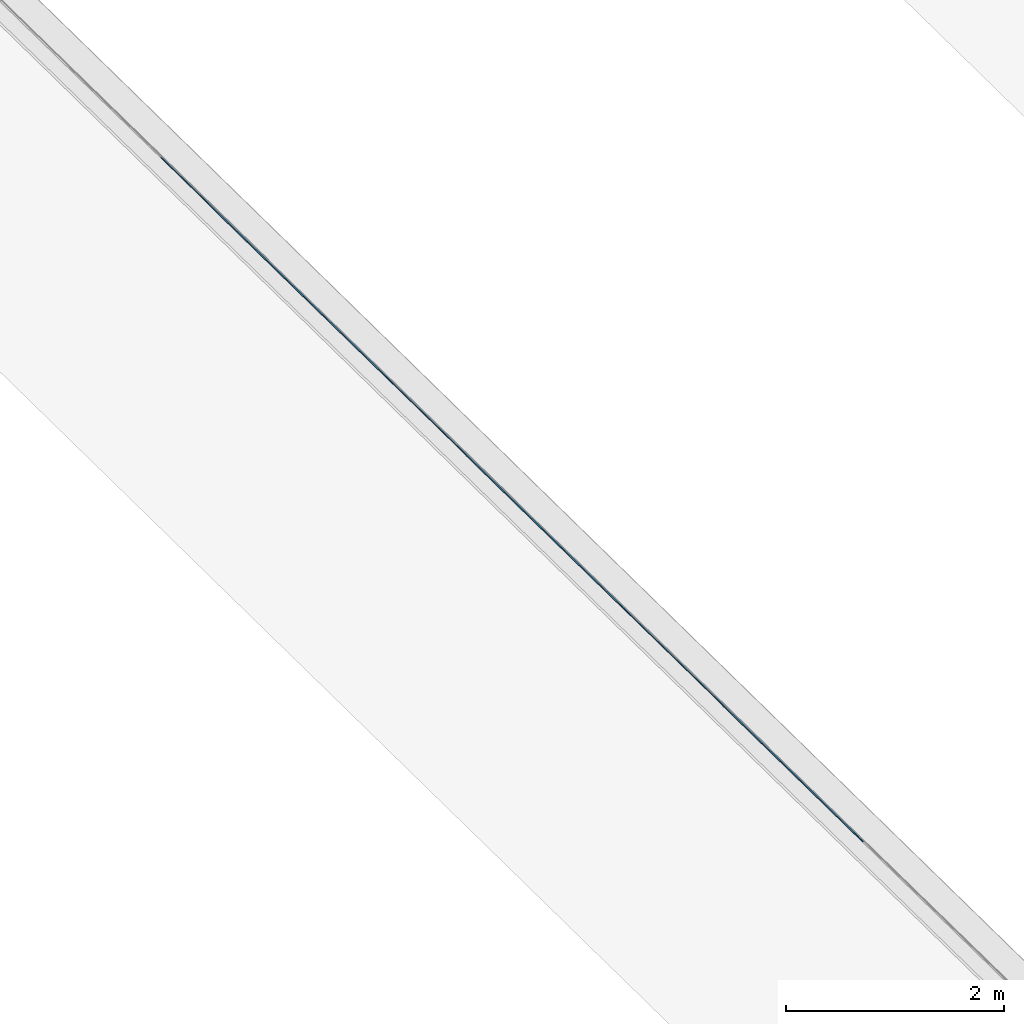
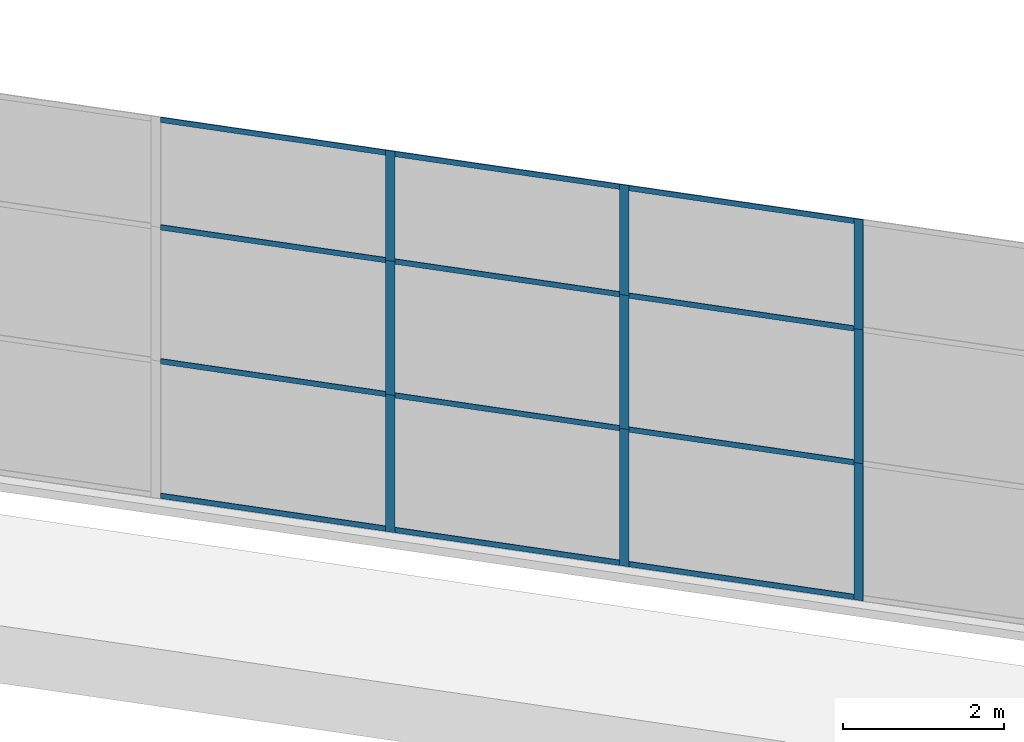
# One storey, part 1 of 13: 21 members, 1 element without a shape of its own.
"""IFC4 building model written with IfcOpenShell, lengths in metres."""

from ifc_helpers import new_model, entity, si_unit, converted_unit, direction, frame, origin, place, context, subcontext, project, spatial, indexed_curve, outline, extrude, source, transform, mapped, material, type_object, type_shapes, element, aggregate, save


model = new_model("IFC4")

# Units and contexts
model_context = context("Model", 3, precision=1e-05, world=origin(), true_north=direction((6.123233995736766e-17, 1.0)))
body_context = subcontext(model_context, "Body", "Model", "MODEL_VIEW")
ifc_project = project(units=[si_unit("LENGTHUNIT", "METRE"), si_unit("AREAUNIT", "SQUARE_METRE"), si_unit("VOLUMEUNIT", "CUBIC_METRE"), converted_unit("PLANEANGLEUNIT", "DEGREE", entity("IfcPlaneAngleMeasure", 0.017453292519943278), si_unit("PLANEANGLEUNIT", "RADIAN"), dimensions=[0, 0, 0, 0, 0, 0, 0])], contexts=[model_context])

# Site, building, storey
site_placement = place(None, frame((0.0, 0.0, 0.0), z_axis=(0.0, 0.0, 1.0), x_axis=(0.7160934825303189, -0.6980043870045516, 0.0)))
site = spatial("IfcSite", under=ifc_project, at=site_placement, CompositionType="ELEMENT")
building_placement = place(site_placement, origin())
building = spatial("IfcBuilding", under=site, at=building_placement, CompositionType="ELEMENT")
storey_placement = place(building_placement, frame((0.0, 0.0, -7.0)))
storey = spatial("IfcBuildingStorey", under=building, at=storey_placement, Name="-7.00 m", CompositionType="ELEMENT", Elevation=-7.000000000000001)

# Curtain wall, members
curtain_wall_type = type_object("IfcCurtainWallType", Name="Facciata continua:Vetrata_2", PredefinedType="NOTDEFINED")
curtain_wall_placement = place(storey_placement, frame((0.0, 0.0, 7.0)))
curtain_wall = element("IfcCurtainWall", 1, at=curtain_wall_placement, inside=storey, type_object=curtain_wall_type, Name="Facciata continua:Vetrata_2", ObjectType="Facciata continua:Vetrata_2", PredefinedType="NOTDEFINED")
ifc_material = material(Name="Acciaio", Category="Metallo")
member_type_1 = type_object("IfcMemberType", Name="Montante rettangolare:Montante rettangolare 2", PredefinedType="MULLION", material=ifc_material)
shared_shape_1 = source(origin(), body_context, "Body", "SweptSolid", [
    extrude(outline(indexed_curve([(-0.04, -0.004999999999999997), (0.04, -0.004999999999999997), (0.04, 0.004999999999999997), (-0.04, 0.004999999999999997), (-0.04, -0.004999999999999997)], self_intersect=False)), frame((-0.04, 0.009999999999999993, -2.8811750164301526), z_axis=(0.0, 0.0, 1.0), x_axis=(-1.0, 0.0, 0.0)), (0.0, 0.0, 1.0), 2.881175016430152),
])
type_shapes(member_type_1, [shared_shape_1])
member_1_placement = place(curtain_wall_placement, frame((-12.786260290149615, -6.977854376535823, -1.1600000000000001), z_axis=(1.0, 0.0, 0.0), x_axis=(0.0, 0.0, 1.0)))
member_1 = element("IfcMember", 2, at=member_1_placement, type_object=member_type_1, material=ifc_material, Name="Montante rettangolare:Montante rettangolare 2", ObjectType="Montante rettangolare:Montante rettangolare 2", PredefinedType="MULLION", context=body_context, shape_type="MappedRepresentation", body=[
    mapped(shared_shape_1, transform((0.0, 0.0, 0.0), scale=1.0)),
])
member_2_placement = place(curtain_wall_placement, frame((-9.785085273719462, -6.9778543765358325, -1.1600000000000001), z_axis=(1.0, 0.0, 0.0), x_axis=(0.0, 0.0, 1.0)))
member_2 = element("IfcMember", 3, at=member_2_placement, type_object=member_type_1, material=ifc_material, Name="Montante rettangolare:Montante rettangolare 2", ObjectType="Montante rettangolare:Montante rettangolare 2", PredefinedType="MULLION", context=body_context, shape_type="MappedRepresentation", body=[
    mapped(shared_shape_1, transform((0.0, 0.0, 0.0), scale=1.0)),
])
member_3_placement = place(curtain_wall_placement, frame((-6.783910257289319, -6.977854376535842, -1.1600000000000001), z_axis=(1.0, 0.0, 0.0), x_axis=(0.0, 0.0, 1.0)))
member_3 = element("IfcMember", 4, at=member_3_placement, type_object=member_type_1, material=ifc_material, Name="Montante rettangolare:Montante rettangolare 2", ObjectType="Montante rettangolare:Montante rettangolare 2", PredefinedType="MULLION", context=body_context, shape_type="MappedRepresentation", body=[
    mapped(shared_shape_1, transform((0.0, 0.0, 0.0), scale=1.0)),
])
member_type_2 = type_object("IfcMemberType", Name="Montante rettangolare:Montante rettangolare 2", PredefinedType="MULLION", material=ifc_material)
shared_shape_2 = source(origin(), body_context, "Body", "SweptSolid", [
    extrude(outline(indexed_curve([(-0.04, -0.004999999999999997), (0.04, -0.004999999999999997), (0.04, 0.004999999999999997), (-0.04, 0.004999999999999997), (-0.04, -0.004999999999999997)], self_intersect=False)), frame((-0.04, 0.009999999999999993, -2.8811750164301455), z_axis=(0.0, 0.0, 1.0), x_axis=(-1.0, 0.0, 0.0)), (0.0, 0.0, 1.0), 2.8811750164301437),
])
type_shapes(member_type_2, [shared_shape_2])
member_4_placement = place(curtain_wall_placement, frame((-15.667435306579762, -6.977854376535813, -6.94), z_axis=(-1.0, 0.0, 0.0), x_axis=(0.0, 0.0, -1.0)))
member_4 = element("IfcMember", 5, at=member_4_placement, type_object=member_type_2, material=ifc_material, Name="Montante rettangolare:Montante rettangolare 2", ObjectType="Montante rettangolare:Montante rettangolare 2", PredefinedType="MULLION", context=body_context, shape_type="MappedRepresentation", body=[
    mapped(shared_shape_2, transform((0.0, 0.0, 0.0), scale=1.0)),
])
member_5_placement = place(curtain_wall_placement, frame((-12.666260290149618, -6.977854376535823, -6.94), z_axis=(-1.0, 0.0, 0.0), x_axis=(0.0, 0.0, -1.0)))
member_5 = element("IfcMember", 6, at=member_5_placement, type_object=member_type_2, material=ifc_material, Name="Montante rettangolare:Montante rettangolare 2", ObjectType="Montante rettangolare:Montante rettangolare 2", PredefinedType="MULLION", context=body_context, shape_type="MappedRepresentation", body=[
    mapped(shared_shape_2, transform((0.0, 0.0, 0.0), scale=1.0)),
])
member_6_placement = place(curtain_wall_placement, frame((-9.665085273719463, -6.9778543765358325, -6.94), z_axis=(-1.0, 0.0, 0.0), x_axis=(0.0, 0.0, -1.0)))
member_6 = element("IfcMember", 7, at=member_6_placement, type_object=member_type_2, material=ifc_material, Name="Montante rettangolare:Montante rettangolare 2", ObjectType="Montante rettangolare:Montante rettangolare 2", PredefinedType="MULLION", context=body_context, shape_type="MappedRepresentation", body=[
    mapped(shared_shape_2, transform((0.0, 0.0, 0.0), scale=1.0)),
])
member_type_3 = type_object("IfcMemberType", Name="Montante rettangolare:Montante rettangolare 2", PredefinedType="MULLION", material=ifc_material)
shared_shape_3 = source(origin(), body_context, "Body", "SweptSolid", [
    extrude(outline(indexed_curve([(-0.04, -0.005000000000000001), (0.04, -0.005000000000000001), (0.04, 0.005000000000000001), (-0.04, 0.005000000000000001), (-0.04, -0.005000000000000001)], self_intersect=False)), frame((0.0, 0.009999999999999998, -2.8811750164301433), z_axis=(0.0, 0.0, 1.0), x_axis=(-1.0, 0.0, 0.0)), (0.0, 0.0, 1.0), 2.8811750164301437),
])
type_shapes(member_type_3, [shared_shape_3])
member_7_placement = place(curtain_wall_placement, frame((-12.786260290149615, -6.977854376535823, -2.829999999999999), z_axis=(1.0, 0.0, 0.0), x_axis=(0.0, 0.0, 1.0)))
member_7 = element("IfcMember", 8, at=member_7_placement, type_object=member_type_3, material=ifc_material, Name="Montante rettangolare:Montante rettangolare 2", ObjectType="Montante rettangolare:Montante rettangolare 2", PredefinedType="MULLION", context=body_context, shape_type="MappedRepresentation", body=[
    mapped(shared_shape_3, transform((0.0, 0.0, 0.0), scale=1.0)),
])
member_8_placement = place(curtain_wall_placement, frame((-9.785085273719462, -6.9778543765358325, -2.829999999999999), z_axis=(1.0, 0.0, 0.0), x_axis=(0.0, 0.0, 1.0)))
member_8 = element("IfcMember", 9, at=member_8_placement, type_object=member_type_3, material=ifc_material, Name="Montante rettangolare:Montante rettangolare 2", ObjectType="Montante rettangolare:Montante rettangolare 2", PredefinedType="MULLION", context=body_context, shape_type="MappedRepresentation", body=[
    mapped(shared_shape_3, transform((0.0, 0.0, 0.0), scale=1.0)),
])
member_9_placement = place(curtain_wall_placement, frame((-6.783910257289319, -6.977854376535842, -2.829999999999999), z_axis=(1.0, 0.0, 0.0), x_axis=(0.0, 0.0, 1.0)))
member_9 = element("IfcMember", 10, at=member_9_placement, type_object=member_type_3, material=ifc_material, Name="Montante rettangolare:Montante rettangolare 2", ObjectType="Montante rettangolare:Montante rettangolare 2", PredefinedType="MULLION", context=body_context, shape_type="MappedRepresentation", body=[
    mapped(shared_shape_3, transform((0.0, 0.0, 0.0), scale=1.0)),
])
member_10_placement = place(curtain_wall_placement, frame((-12.786260290149617, -6.977854376535823, -4.86), z_axis=(1.0, 0.0, 0.0), x_axis=(0.0, 0.0, 1.0)))
member_10 = element("IfcMember", 11, at=member_10_placement, type_object=member_type_3, material=ifc_material, Name="Montante rettangolare:Montante rettangolare 2", ObjectType="Montante rettangolare:Montante rettangolare 2", PredefinedType="MULLION", context=body_context, shape_type="MappedRepresentation", body=[
    mapped(shared_shape_3, transform((0.0, 0.0, 0.0), scale=1.0)),
])
member_11_placement = place(curtain_wall_placement, frame((-9.785085273719462, -6.9778543765358325, -4.86), z_axis=(1.0, 0.0, 0.0), x_axis=(0.0, 0.0, 1.0)))
member_11 = element("IfcMember", 12, at=member_11_placement, type_object=member_type_3, material=ifc_material, Name="Montante rettangolare:Montante rettangolare 2", ObjectType="Montante rettangolare:Montante rettangolare 2", PredefinedType="MULLION", context=body_context, shape_type="MappedRepresentation", body=[
    mapped(shared_shape_3, transform((0.0, 0.0, 0.0), scale=1.0)),
])
member_12_placement = place(curtain_wall_placement, frame((-6.783910257289319, -6.977854376535842, -4.86), z_axis=(1.0, 0.0, 0.0), x_axis=(0.0, 0.0, 1.0)))
member_12 = element("IfcMember", 13, at=member_12_placement, type_object=member_type_3, material=ifc_material, Name="Montante rettangolare:Montante rettangolare 2", ObjectType="Montante rettangolare:Montante rettangolare 2", PredefinedType="MULLION", context=body_context, shape_type="MappedRepresentation", body=[
    mapped(shared_shape_3, transform((0.0, 0.0, 0.0), scale=1.0)),
])
member_type_4 = type_object("IfcMemberType", Name="Montante rettangolare:Montante rettangolare 3", PredefinedType="MULLION", material=ifc_material)
shared_shape_4 = source(origin(), body_context, "Body", "SweptSolid", [
    extrude(outline(indexed_curve([(-0.06, -0.005000000000000001), (0.06, -0.005000000000000001), (0.06, 0.005000000000000001), (-0.06, 0.005000000000000001), (-0.06, -0.005000000000000001)], self_intersect=False)), frame((0.0, 0.009999999999999998, -2.0800000000000005), z_axis=(0.0, 0.0, 1.0), x_axis=(-1.0, 0.0, 0.0)), (0.0, 0.0, 1.0), 2.0800000000000005),
])
type_shapes(member_type_4, [shared_shape_4])
member_13_placement = place(curtain_wall_placement, frame((-12.726260290149616, -6.977854376535823, -6.94), z_axis=(0.0, 0.0, -1.0), x_axis=(1.0, 0.0, 0.0)))
member_13 = element("IfcMember", 14, at=member_13_placement, type_object=member_type_4, material=ifc_material, Name="Montante rettangolare:Montante rettangolare 3", ObjectType="Montante rettangolare:Montante rettangolare 3", PredefinedType="MULLION", context=body_context, shape_type="MappedRepresentation", body=[
    mapped(shared_shape_4, transform((0.0, 0.0, 0.0), scale=1.0)),
])
member_14_placement = place(curtain_wall_placement, frame((-9.725085273719463, -6.9778543765358325, -6.94), z_axis=(0.0, 0.0, -1.0), x_axis=(1.0, 0.0, 0.0)))
member_14 = element("IfcMember", 15, at=member_14_placement, type_object=member_type_4, material=ifc_material, Name="Montante rettangolare:Montante rettangolare 3", ObjectType="Montante rettangolare:Montante rettangolare 3", PredefinedType="MULLION", context=body_context, shape_type="MappedRepresentation", body=[
    mapped(shared_shape_4, transform((0.0, 0.0, 0.0), scale=1.0)),
])
member_15_placement = place(curtain_wall_placement, frame((-6.723910257289319, -6.977854376535842, -6.94), z_axis=(0.0, 0.0, -1.0), x_axis=(1.0, 0.0, 0.0)))
member_15 = element("IfcMember", 16, at=member_15_placement, type_object=member_type_4, material=ifc_material, Name="Montante rettangolare:Montante rettangolare 3", ObjectType="Montante rettangolare:Montante rettangolare 3", PredefinedType="MULLION", context=body_context, shape_type="MappedRepresentation", body=[
    mapped(shared_shape_4, transform((0.0, 0.0, 0.0), scale=1.0)),
])
member_type_5 = type_object("IfcMemberType", Name="Montante rettangolare:Montante rettangolare 3", PredefinedType="MULLION", material=ifc_material)
shared_shape_5 = source(origin(), body_context, "Body", "SweptSolid", [
    extrude(outline(indexed_curve([(-0.06, -0.005000000000000001), (0.06, -0.005000000000000001), (0.06, 0.005000000000000001), (-0.06, 0.005000000000000001), (-0.06, -0.005000000000000001)], self_intersect=False)), frame((0.0, 0.009999999999999998, -1.6699999999999993), z_axis=(0.0, 0.0, 1.0), x_axis=(-1.0, 0.0, 0.0)), (0.0, 0.0, 1.0), 1.6699999999999993),
])
type_shapes(member_type_5, [shared_shape_5])
member_16_placement = place(curtain_wall_placement, frame((-12.726260290149614, -6.977854376535823, -2.829999999999999), z_axis=(0.0, 0.0, -1.0), x_axis=(1.0, 0.0, 0.0)))
member_16 = element("IfcMember", 17, at=member_16_placement, type_object=member_type_5, material=ifc_material, Name="Montante rettangolare:Montante rettangolare 3", ObjectType="Montante rettangolare:Montante rettangolare 3", PredefinedType="MULLION", context=body_context, shape_type="MappedRepresentation", body=[
    mapped(shared_shape_5, transform((0.0, 0.0, 0.0), scale=1.0)),
])
member_17_placement = place(curtain_wall_placement, frame((-9.725085273719463, -6.9778543765358325, -2.829999999999999), z_axis=(0.0, 0.0, -1.0), x_axis=(1.0, 0.0, 0.0)))
member_17 = element("IfcMember", 18, at=member_17_placement, type_object=member_type_5, material=ifc_material, Name="Montante rettangolare:Montante rettangolare 3", ObjectType="Montante rettangolare:Montante rettangolare 3", PredefinedType="MULLION", context=body_context, shape_type="MappedRepresentation", body=[
    mapped(shared_shape_5, transform((0.0, 0.0, 0.0), scale=1.0)),
])
member_18_placement = place(curtain_wall_placement, frame((-6.723910257289319, -6.977854376535842, -2.829999999999999), z_axis=(0.0, 0.0, -1.0), x_axis=(1.0, 0.0, 0.0)))
member_18 = element("IfcMember", 19, at=member_18_placement, type_object=member_type_5, material=ifc_material, Name="Montante rettangolare:Montante rettangolare 3", ObjectType="Montante rettangolare:Montante rettangolare 3", PredefinedType="MULLION", context=body_context, shape_type="MappedRepresentation", body=[
    mapped(shared_shape_5, transform((0.0, 0.0, 0.0), scale=1.0)),
])
member_type_6 = type_object("IfcMemberType", Name="Montante rettangolare:Montante rettangolare 3", PredefinedType="MULLION", material=ifc_material)
shared_shape_6 = source(origin(), body_context, "Body", "SweptSolid", [
    extrude(outline(indexed_curve([(-0.06, -0.005000000000000001), (0.06, -0.005000000000000001), (0.06, 0.005000000000000001), (-0.06, 0.005000000000000001), (-0.06, -0.005000000000000001)], self_intersect=False)), frame((0.0, 0.009999999999999998, -2.030000000000001), z_axis=(0.0, 0.0, 1.0), x_axis=(-1.0, 0.0, 0.0)), (0.0, 0.0, 1.0), 2.030000000000001),
])
type_shapes(member_type_6, [shared_shape_6])
member_19_placement = place(curtain_wall_placement, frame((-12.726260290149616, -6.977854376535823, -4.86), z_axis=(0.0, 0.0, -1.0), x_axis=(1.0, 0.0, 0.0)))
member_19 = element("IfcMember", 20, at=member_19_placement, type_object=member_type_6, material=ifc_material, Name="Montante rettangolare:Montante rettangolare 3", ObjectType="Montante rettangolare:Montante rettangolare 3", PredefinedType="MULLION", context=body_context, shape_type="MappedRepresentation", body=[
    mapped(shared_shape_6, transform((0.0, 0.0, 0.0), scale=1.0)),
])
member_20_placement = place(curtain_wall_placement, frame((-9.725085273719463, -6.9778543765358325, -4.86), z_axis=(0.0, 0.0, -1.0), x_axis=(1.0, 0.0, 0.0)))
member_20 = element("IfcMember", 21, at=member_20_placement, type_object=member_type_6, material=ifc_material, Name="Montante rettangolare:Montante rettangolare 3", ObjectType="Montante rettangolare:Montante rettangolare 3", PredefinedType="MULLION", context=body_context, shape_type="MappedRepresentation", body=[
    mapped(shared_shape_6, transform((0.0, 0.0, 0.0), scale=1.0)),
])
member_21_placement = place(curtain_wall_placement, frame((-6.723910257289319, -6.977854376535842, -4.86), z_axis=(0.0, 0.0, -1.0), x_axis=(1.0, 0.0, 0.0)))
member_21 = element("IfcMember", 22, at=member_21_placement, type_object=member_type_6, material=ifc_material, Name="Montante rettangolare:Montante rettangolare 3", ObjectType="Montante rettangolare:Montante rettangolare 3", PredefinedType="MULLION", context=body_context, shape_type="MappedRepresentation", body=[
    mapped(shared_shape_6, transform((0.0, 0.0, 0.0), scale=1.0)),
])
aggregate(curtain_wall, [member_1, member_2, member_3, member_4, member_5, member_6, member_7, member_8, member_9, member_10, member_11, member_12, member_13, member_14, member_15, member_16, member_17, member_18, member_19, member_20, member_21])

save(model, "model.ifc")
